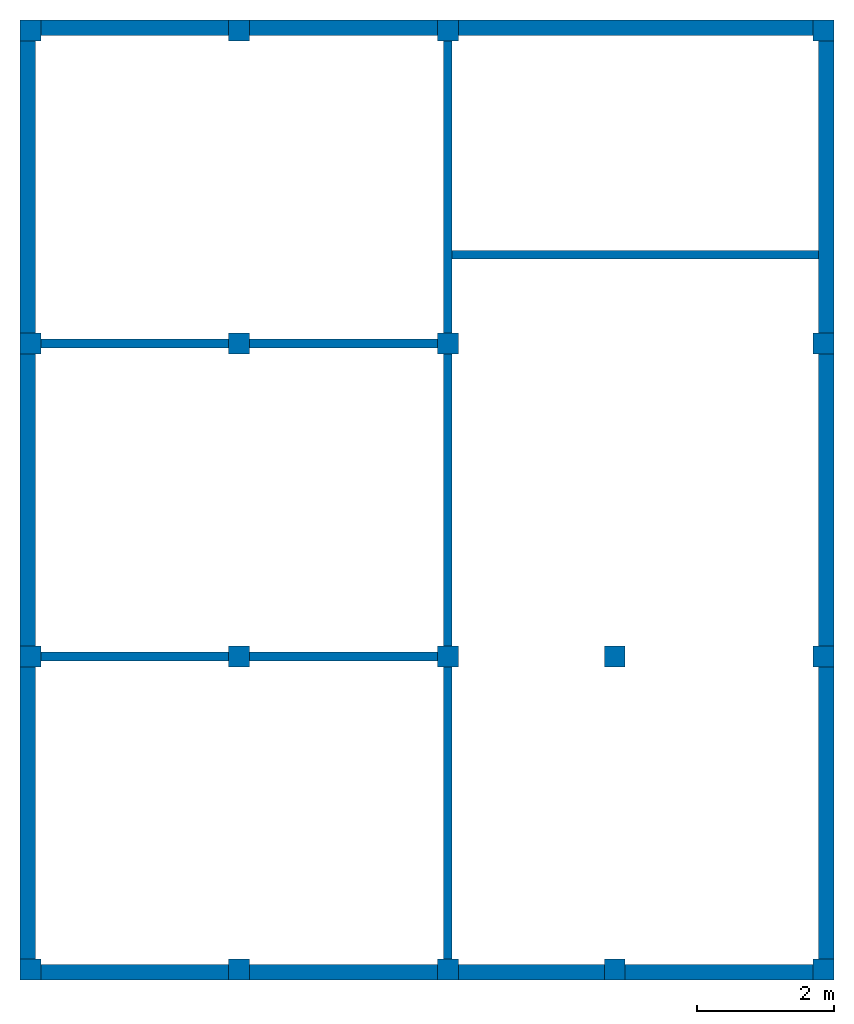
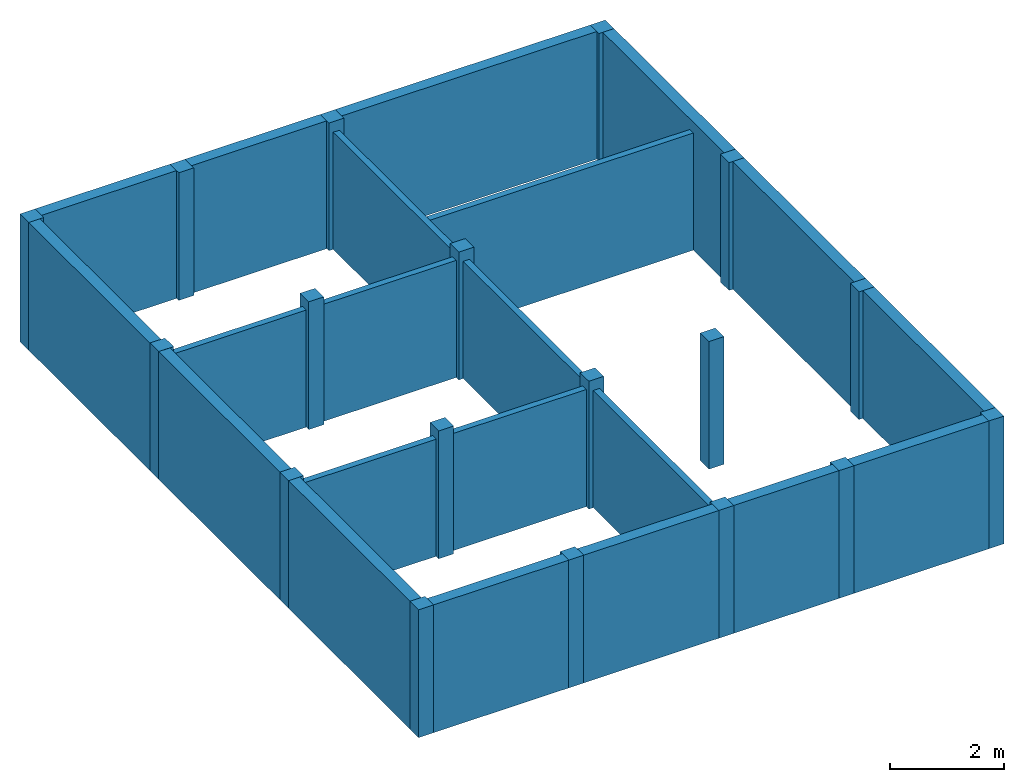
# One storey: 18 columns, 10 walls.
"""IFC2X3 building model written with IfcOpenShell, lengths in feet."""

from ifc_helpers import new_model, entity, si_unit, converted_unit, derived_unit, direction, frame, frame_2d, origin, origin_2d_with_axis, place, context, subcontext, project, spatial, rectangle, extrude, source, transform, mapped, material, layer, layer_set, layer_usage, type_object, type_shapes, element, save


model = new_model("IFC2X3")

# Units and contexts
model_context = context("Model", 3, precision=0.0001, world=origin(), true_north=direction((6.123031769111886e-17, 1.0)))
body_context = subcontext(model_context, "Body", "Model", "MODEL_VIEW")
ifc_project = project(units=[converted_unit("LENGTHUNIT", "FOOT", entity("IfcLengthMeasure", 0.3048), si_unit("LENGTHUNIT", "METRE"), dimensions=[1, 0, 0, 0, 0, 0, 0]), converted_unit("AREAUNIT", "SQUARE FOOT", entity("IfcAreaMeasure", 0.09290304), si_unit("AREAUNIT", "SQUARE_METRE"), dimensions=[2, 0, 0, 0, 0, 0, 0]), converted_unit("VOLUMEUNIT", "CUBIC FOOT", entity("IfcVolumeMeasure", 0.028316846592000004), si_unit("VOLUMEUNIT", "CUBIC_METRE"), dimensions=[3, 0, 0, 0, 0, 0, 0]), converted_unit("PLANEANGLEUNIT", "DEGREE", entity("IfcPlaneAngleMeasure", 0.017453292519943278), si_unit("PLANEANGLEUNIT", "RADIAN"), dimensions=[0, 0, 0, 0, 0, 0, 0]), si_unit("MASSUNIT", "GRAM", prefix="KILO"), derived_unit("MASSDENSITYUNIT", [(si_unit("MASSUNIT", "GRAM", prefix="KILO"), 1), (si_unit("LENGTHUNIT", "METRE"), -3)]), derived_unit("IONCONCENTRATIONUNIT", [(si_unit("MASSUNIT", "GRAM", prefix="KILO"), 1), (si_unit("LENGTHUNIT", "METRE"), -3)]), derived_unit("MOMENTOFINERTIAUNIT", [(si_unit("LENGTHUNIT", "METRE"), 4)]), si_unit("TIMEUNIT", "SECOND"), si_unit("FREQUENCYUNIT", "HERTZ"), si_unit("THERMODYNAMICTEMPERATUREUNIT", "DEGREE_CELSIUS"), derived_unit("THERMALTRANSMITTANCEUNIT", [(si_unit("MASSUNIT", "GRAM", prefix="KILO"), 1), (si_unit("THERMODYNAMICTEMPERATUREUNIT", "KELVIN"), -1), (si_unit("TIMEUNIT", "SECOND"), -3)]), derived_unit("THERMALCONDUCTANCEUNIT", [(si_unit("MASSUNIT", "GRAM", prefix="KILO"), 1), (si_unit("THERMODYNAMICTEMPERATUREUNIT", "KELVIN"), -1), (si_unit("TIMEUNIT", "SECOND"), -3), (si_unit("LENGTHUNIT", "METRE"), 1)]), derived_unit("VOLUMETRICFLOWRATEUNIT", [(si_unit("LENGTHUNIT", "METRE"), 3), (si_unit("TIMEUNIT", "SECOND"), -1)]), derived_unit("MASSFLOWRATEUNIT", [(si_unit("MASSUNIT", "GRAM", prefix="KILO"), 1), (si_unit("TIMEUNIT", "SECOND"), -1)]), derived_unit("ROTATIONALFREQUENCYUNIT", [(si_unit("TIMEUNIT", "SECOND"), -1)]), si_unit("ELECTRICCURRENTUNIT", "AMPERE"), si_unit("ELECTRICVOLTAGEUNIT", "VOLT"), si_unit("POWERUNIT", "WATT"), converted_unit("FORCEUNIT", "KIP", entity("IfcForceMeasure", 2.088543423315013e-05), si_unit("FORCEUNIT", "NEWTON"), dimensions=[1, 1, -2, 0, 0, 0, 0]), si_unit("ILLUMINANCEUNIT", "LUX"), si_unit("LUMINOUSFLUXUNIT", "LUMEN"), si_unit("LUMINOUSINTENSITYUNIT", "CANDELA"), si_unit("ENERGYUNIT", "JOULE"), derived_unit("USERDEFINED", [(si_unit("MASSUNIT", "GRAM", prefix="KILO"), -1), (si_unit("LENGTHUNIT", "METRE"), -2), (si_unit("TIMEUNIT", "SECOND"), 3), (si_unit("LUMINOUSFLUXUNIT", "LUMEN"), 1)]), derived_unit("USERDEFINED", [(si_unit("MASSUNIT", "GRAM", prefix="KILO"), 1), (si_unit("TIMEUNIT", "SECOND"), -3), (si_unit("LENGTHUNIT", "METRE"), 3), (si_unit("ELECTRICCURRENTUNIT", "AMPERE"), -2)]), derived_unit("SOUNDPOWERUNIT", [(si_unit("MASSUNIT", "GRAM", prefix="KILO"), 1), (si_unit("TIMEUNIT", "SECOND"), -3), (si_unit("LENGTHUNIT", "METRE"), 2)]), derived_unit("SOUNDPRESSUREUNIT", [(si_unit("MASSUNIT", "GRAM", prefix="KILO"), 1), (si_unit("LENGTHUNIT", "METRE"), -1), (si_unit("TIMEUNIT", "SECOND"), -2)]), derived_unit("LINEARVELOCITYUNIT", [(si_unit("LENGTHUNIT", "METRE"), 1), (si_unit("TIMEUNIT", "SECOND"), -1)]), si_unit("PRESSUREUNIT", "PASCAL"), derived_unit("USERDEFINED", [(si_unit("MASSUNIT", "GRAM", prefix="KILO"), 1), (si_unit("LENGTHUNIT", "METRE"), -2), (si_unit("TIMEUNIT", "SECOND"), -2)]), derived_unit("LINEARFORCEUNIT", [(si_unit("MASSUNIT", "GRAM", prefix="KILO"), 1), (si_unit("TIMEUNIT", "SECOND"), -2)]), derived_unit("PLANARFORCEUNIT", [(si_unit("MASSUNIT", "GRAM", prefix="KILO"), 1), (si_unit("LENGTHUNIT", "METRE"), -1), (si_unit("TIMEUNIT", "SECOND"), -2)]), derived_unit("SPECIFICHEATCAPACITYUNIT", [(si_unit("THERMODYNAMICTEMPERATUREUNIT", "KELVIN"), -1), (si_unit("LENGTHUNIT", "METRE"), 2), (si_unit("TIMEUNIT", "SECOND"), -2)]), derived_unit("HEATFLUXDENSITYUNIT", [(si_unit("MASSUNIT", "GRAM", prefix="KILO"), 1), (si_unit("TIMEUNIT", "SECOND"), -3)]), derived_unit("HEATINGVALUEUNIT", [(si_unit("LENGTHUNIT", "METRE"), 2), (si_unit("TIMEUNIT", "SECOND"), -2)]), derived_unit("VAPORPERMEABILITYUNIT", [(si_unit("LENGTHUNIT", "METRE"), -1), (si_unit("TIMEUNIT", "SECOND"), 1)]), derived_unit("DYNAMICVISCOSITYUNIT", [(si_unit("MASSUNIT", "GRAM", prefix="KILO"), 1), (si_unit("TIMEUNIT", "SECOND"), -1), (si_unit("LENGTHUNIT", "METRE"), -1)]), derived_unit("THERMALEXPANSIONCOEFFICIENTUNIT", [(si_unit("THERMODYNAMICTEMPERATUREUNIT", "KELVIN"), -1)]), derived_unit("MODULUSOFELASTICITYUNIT", [(si_unit("MASSUNIT", "GRAM", prefix="KILO"), 1), (si_unit("LENGTHUNIT", "METRE"), -1), (si_unit("TIMEUNIT", "SECOND"), -2)]), derived_unit("ISOTHERMALMOISTURECAPACITYUNIT", [(si_unit("LENGTHUNIT", "METRE"), 3), (si_unit("MASSUNIT", "GRAM", prefix="KILO"), -1)]), derived_unit("MOISTUREDIFFUSIVITYUNIT", [(si_unit("TIMEUNIT", "SECOND"), -1), (si_unit("LENGTHUNIT", "METRE"), 2)]), derived_unit("MASSPERLENGTHUNIT", [(si_unit("MASSUNIT", "GRAM", prefix="KILO"), 1), (si_unit("LENGTHUNIT", "METRE"), -1)]), derived_unit("THERMALRESISTANCEUNIT", [(si_unit("MASSUNIT", "GRAM", prefix="KILO"), -1), (si_unit("TIMEUNIT", "SECOND"), 3), (si_unit("THERMODYNAMICTEMPERATUREUNIT", "KELVIN"), 1)]), derived_unit("ACCELERATIONUNIT", [(si_unit("LENGTHUNIT", "METRE"), 1), (si_unit("TIMEUNIT", "SECOND"), -2)]), derived_unit("ANGULARVELOCITYUNIT", [(si_unit("TIMEUNIT", "SECOND"), -1), (si_unit("PLANEANGLEUNIT", "RADIAN"), 1)]), derived_unit("LINEARSTIFFNESSUNIT", [(si_unit("MASSUNIT", "GRAM", prefix="KILO"), 1), (si_unit("TIMEUNIT", "SECOND"), -2)]), derived_unit("WARPINGCONSTANTUNIT", [(si_unit("LENGTHUNIT", "METRE"), 6)]), derived_unit("LINEARMOMENTUNIT", [(si_unit("MASSUNIT", "GRAM", prefix="KILO"), 1), (si_unit("LENGTHUNIT", "METRE"), 1), (si_unit("TIMEUNIT", "SECOND"), -2)]), derived_unit("TORQUEUNIT", [(si_unit("MASSUNIT", "GRAM", prefix="KILO"), 1), (si_unit("LENGTHUNIT", "METRE"), 2), (si_unit("TIMEUNIT", "SECOND"), -2)])], contexts=[model_context])

# Site, building, storey
site_placement = place(None, origin())
site = spatial("IfcSite", under=ifc_project, at=site_placement, CompositionType="ELEMENT")
building_placement = place(site_placement, origin())
building = spatial("IfcBuilding", under=site, at=building_placement, CompositionType="ELEMENT")
storey_placement = place(building_placement, frame((0.0, 0.0, 18.833333333333574)))
storey = spatial("IfcBuildingStorey", under=building, at=storey_placement, Name="Second Floor", CompositionType="ELEMENT", Elevation=18.833333333333574)

# Columns
ifc_material_1 = material(Name="Concrete, Cast-in-Place gray")
column_type = type_object("IfcColumnType", PredefinedType="COLUMN", material=ifc_material_1)
shared_shape = source(origin(), body_context, "Body", "SweptSolid", [
    extrude(rectangle(XDim=0.9999999999999999, YDim=0.9999999999999999, at=origin_2d_with_axis()), frame((0.0, 0.0, 18.833333333333574), z_axis=(0.0, 0.0, 1.0), x_axis=(-1.0, 0.0, 0.0)), (0.0, 0.0, 1.0), 9.00000000000162),
])
type_shapes(column_type, [shared_shape])
for number, where in (
    (1, (9.874478019162162, -49.84124484724893, -18.833333333333574)),
    (2, (29.874478019162154, -49.841244847248994, -18.833333333333574)),
    (3, (37.87447801916216, -49.84124484724902, -18.833333333333574)),
    (4, (47.87447801916217, -49.84124484724906, -18.833333333333574)),
    (5, (19.874478019162158, -49.841244847248966, -18.833333333333574)),
    (6, (9.874478019162186, -34.84124484724893, -18.833333333333574)),
    (7, (29.87447801916219, -34.841244847248994, -18.833333333333574)),
    (8, (37.87447801916219, -34.84124484724902, -18.833333333333574)),
    (9, (47.87447801916219, -34.84124484724906, -18.833333333333574)),
    (10, (19.874478019162183, -34.841244847248966, -18.833333333333574)),
    (11, (9.874478019162211, -19.841244847248934, -18.833333333333574)),
    (12, (29.87447801916221, -19.841244847248998, -18.833333333333574)),
    (13, (47.87447801916221, -19.841244847249058, -18.833333333333574)),
    (14, (19.874478019162204, -19.841244847248966, -18.833333333333574)),
    (15, (9.874478019162234, -4.841244847248884, -18.833333333333574)),
    (16, (29.874478019162233, -4.841244847248948, -18.833333333333574)),
    (17, (47.87447801916224, -4.841244847249006, -18.833333333333574)),
    (18, (19.87447801916223, -4.841244847248915, -18.833333333333574)),
):
    element("IfcColumn", number, at=place(storey_placement, frame(where)), inside=storey, type_object=column_type, material=ifc_material_1, context=body_context, shape_type="MappedRepresentation", body=[
        mapped(shared_shape, transform((0.0, 0.0, 0.0), scale=1.0)),
    ])

# Walls
ifc_material_2 = material(Name="Default Wall")
ifc_layer_1 = layer(ifc_material_2, 0.75)
ifc_layer_set_1 = layer_set([ifc_layer_1])
ifc_layer_usage_1 = layer_usage(ifc_layer_set_1, "AXIS2", "NEGATIVE", 0.375)
wall_type_1 = type_object("IfcWallType", PredefinedType="STANDARD", material=ifc_layer_set_1)
wall_1_placement = place(storey_placement, frame((9.374478019162236, -4.716244847248882, 0.0)))
element("IfcWallStandardCase", 19, at=wall_1_placement, inside=storey, type_object=wall_type_1, material=ifc_layer_usage_1, context=body_context, shape_type="SweptSolid", body=[
    extrude(rectangle(XDim=38.24999999999993, YDim=0.75, at=frame_2d((19.124999999999964, 0.0), x_axis=(-1.0, 0.0))), origin(), (0.0, 0.0, 1.0), 9.00000000000162),
])
wall_2_placement = place(storey_placement, frame((9.749478019162236, -50.34124484724887, 0.0), z_axis=(0.0, 0.0, 1.0), x_axis=(0.0, 1.0, 0.0)))
element("IfcWallStandardCase", 20, at=wall_2_placement, inside=storey, type_object=wall_type_1, material=ifc_layer_usage_1, context=body_context, shape_type="SweptSolid", body=[
    extrude(rectangle(XDim=45.24999999999999, YDim=0.75, at=frame_2d((22.624999999999996, 0.0), x_axis=(-1.0, 0.0))), origin(), (0.0, 0.0, 1.0), 9.00000000000162),
])
wall_3_placement = place(storey_placement, frame((48.37447801916217, -49.96624484724888, 0.0), z_axis=(0.0, 0.0, 1.0), x_axis=(-1.0, 0.0, 0.0)))
element("IfcWallStandardCase", 21, at=wall_3_placement, inside=storey, type_object=wall_type_1, material=ifc_layer_usage_1, context=body_context, shape_type="SweptSolid", body=[
    extrude(rectangle(XDim=38.249999999999936, YDim=0.75, at=frame_2d((19.124999999999968, 0.0), x_axis=(-1.0, 0.0))), origin(), (0.0, 0.0, 1.0), 9.00000000000162),
])
wall_4_placement = place(storey_placement, frame((47.99947801916217, -4.3412448472488805, 0.0), z_axis=(0.0, 0.0, 1.0), x_axis=(0.0, -1.0, 0.0)))
element("IfcWallStandardCase", 22, at=wall_4_placement, inside=storey, type_object=wall_type_1, material=ifc_layer_usage_1, context=body_context, shape_type="SweptSolid", body=[
    extrude(rectangle(XDim=45.25, YDim=0.75, at=frame_2d((22.625, 0.0), x_axis=(-1.0, 0.0))), origin(), (0.0, 0.0, 1.0), 9.00000000000162),
])
ifc_layer_2 = layer(ifc_material_2, 0.4166666666666667)
ifc_layer_set_2 = layer_set([ifc_layer_2])
ifc_layer_usage_2 = layer_usage(ifc_layer_set_2, "AXIS2", "NEGATIVE", 0.20833333333333334)
wall_type_2 = type_object("IfcWallType", PredefinedType="STANDARD", material=ifc_layer_set_2)
wall_5_placement = place(storey_placement, frame((10.37447801916221, -19.841244847248937, 0.0)))
element("IfcWallStandardCase", 23, at=wall_5_placement, inside=storey, type_object=wall_type_2, material=ifc_layer_usage_2, context=body_context, shape_type="SweptSolid", body=[
    extrude(rectangle(XDim=19.0, YDim=0.4166666666666643, at=frame_2d((9.5, 0.0), x_axis=(-1.0, 0.0))), origin(), (0.0, 0.0, 1.0), 8.249999999998622),
])
wall_6_placement = place(storey_placement, frame((29.87447801916221, -19.341244847248994, 0.0), z_axis=(0.0, 0.0, 1.0), x_axis=(0.0, 1.0, 0.0)))
element("IfcWallStandardCase", 24, at=wall_6_placement, inside=storey, type_object=wall_type_2, material=ifc_layer_usage_2, context=body_context, shape_type="SweptSolid", body=[
    extrude(rectangle(XDim=14.000000000000046, YDim=0.4166666666666643, at=frame_2d((7.000000000000023, 0.0), x_axis=(-1.0, 0.0))), origin(), (0.0, 0.0, 1.0), 8.249999999998622),
])
wall_7_placement = place(storey_placement, frame((29.87447801916221, -20.341244847249, 0.0), z_axis=(0.0, 0.0, 1.0), x_axis=(0.0, -1.0, 0.0)))
element("IfcWallStandardCase", 25, at=wall_7_placement, inside=storey, type_object=wall_type_2, material=ifc_layer_usage_2, context=body_context, shape_type="SweptSolid", body=[
    extrude(rectangle(XDim=13.999999999999986, YDim=0.4166666666666643, at=frame_2d((6.999999999999993, 0.0), x_axis=(-1.0, 0.0))), origin(), (0.0, 0.0, 1.0), 8.249999999998622),
])
wall_8_placement = place(storey_placement, frame((29.37447801916219, -34.841244847248994, 0.0), z_axis=(0.0, 0.0, 1.0), x_axis=(-1.0, 0.0, 0.0)))
element("IfcWallStandardCase", 26, at=wall_8_placement, inside=storey, type_object=wall_type_2, material=ifc_layer_usage_2, context=body_context, shape_type="SweptSolid", body=[
    extrude(rectangle(XDim=19.000000000000007, YDim=0.4166666666666714, at=frame_2d((9.500000000000004, 0.0), x_axis=(-1.0, 0.0))), origin(), (0.0, 0.0, 1.0), 8.249999999998622),
])
wall_9_placement = place(storey_placement, frame((29.87447801916219, -35.341244847249, 0.0), z_axis=(0.0, 0.0, 1.0), x_axis=(0.0, -1.0, 0.0)))
element("IfcWallStandardCase", 27, at=wall_9_placement, inside=storey, type_object=wall_type_2, material=ifc_layer_usage_2, context=body_context, shape_type="SweptSolid", body=[
    extrude(rectangle(XDim=13.999999999999986, YDim=0.4166666666666643, at=frame_2d((6.999999999999993, 0.0), x_axis=(-1.0, 0.0))), origin(), (0.0, 0.0, 1.0), 8.249999999998622),
])
wall_10_placement = place(storey_placement, frame((30.082811352495554, -15.591244847248992, 0.0)))
element("IfcWallStandardCase", 28, at=wall_10_placement, inside=storey, type_object=wall_type_2, material=ifc_layer_usage_2, context=body_context, shape_type="SweptSolid", body=[
    extrude(rectangle(XDim=17.541666666666615, YDim=0.41666666666666785, at=frame_2d((8.770833333333307, 0.0), x_axis=(-1.0, 0.0))), origin(), (0.0, 0.0, 1.0), 8.249999999998622),
])

save(model, "model.ifc")
